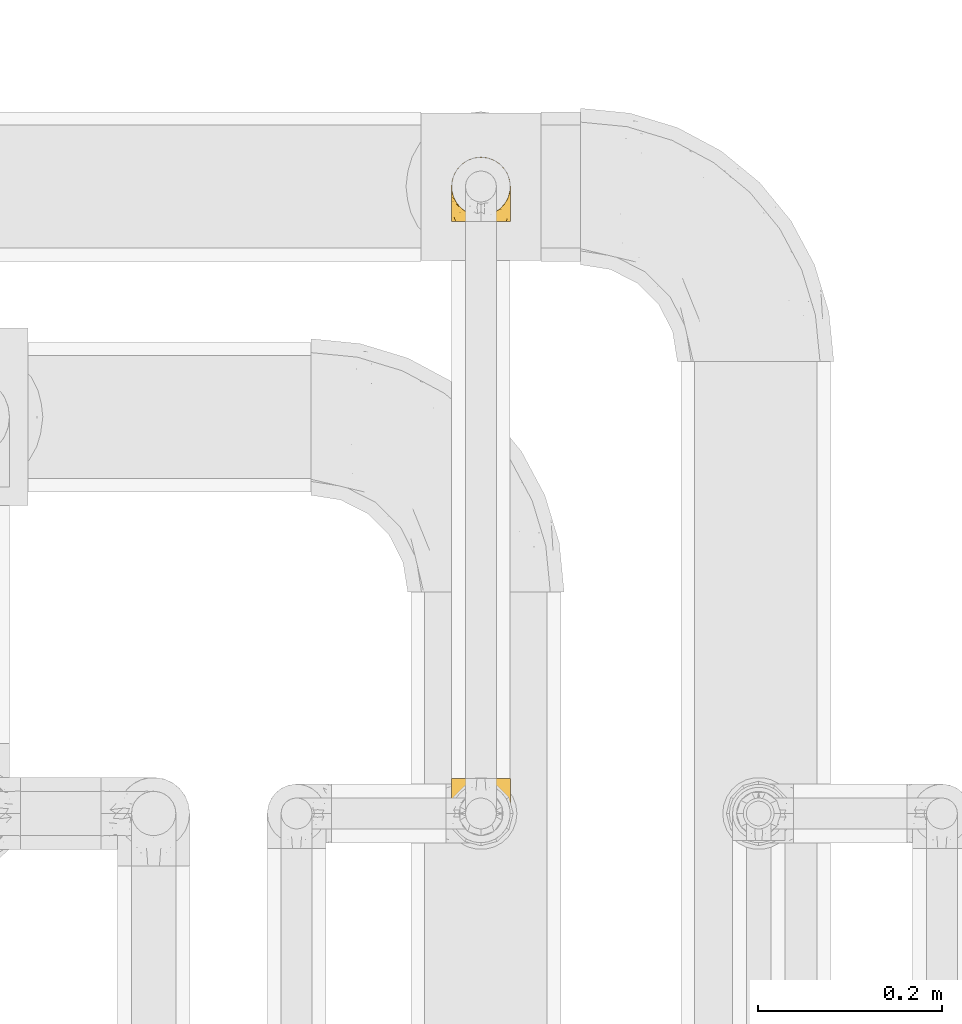
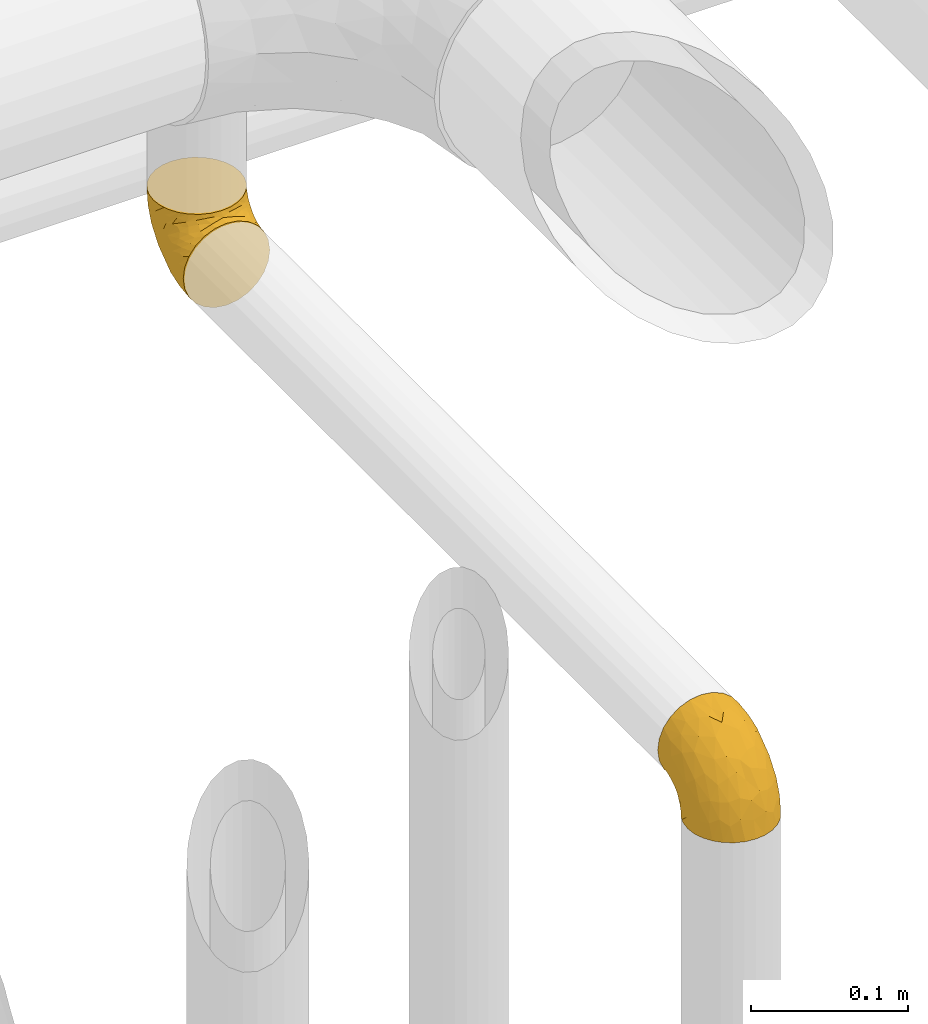
# One storey, part 504 of 827: 2 coverings.
"""IFC2X3 building model written with IfcOpenShell, lengths in millimetres."""

from ifc_helpers import new_model, entity, si_unit, converted_unit, derived_unit, direction, frame, origin, place, context, subcontext, project, spatial, faceted_brep, element, save


model = new_model("IFC2X3")

# Units and contexts
model_context = context("Model", 3, precision=0.01, world=origin(), true_north=direction((6.12303176911189e-17, 1.0)))
body_context = subcontext(model_context, "Body", "Model", "MODEL_VIEW")
ifc_project = project(units=[si_unit("LENGTHUNIT", "METRE", prefix="MILLI"), si_unit("AREAUNIT", "SQUARE_METRE"), si_unit("VOLUMEUNIT", "CUBIC_METRE"), converted_unit("PLANEANGLEUNIT", "DEGREE", entity("IfcRatioMeasure", 0.0174532925199433), si_unit("PLANEANGLEUNIT", "RADIAN"), dimensions=[0, 0, 0, 0, 0, 0, 0]), si_unit("MASSUNIT", "GRAM", prefix="KILO"), derived_unit("MASSDENSITYUNIT", [(si_unit("MASSUNIT", "GRAM", prefix="KILO"), 1), (si_unit("LENGTHUNIT", "METRE"), -3)]), derived_unit("MOMENTOFINERTIAUNIT", [(si_unit("LENGTHUNIT", "METRE"), 4)]), si_unit("TIMEUNIT", "SECOND"), si_unit("FREQUENCYUNIT", "HERTZ"), si_unit("THERMODYNAMICTEMPERATUREUNIT", "DEGREE_CELSIUS"), derived_unit("THERMALTRANSMITTANCEUNIT", [(si_unit("MASSUNIT", "GRAM", prefix="KILO"), 1), (si_unit("THERMODYNAMICTEMPERATUREUNIT", "KELVIN"), -1), (si_unit("TIMEUNIT", "SECOND"), -3)]), derived_unit("VOLUMETRICFLOWRATEUNIT", [(si_unit("LENGTHUNIT", "METRE"), 3), (si_unit("TIMEUNIT", "SECOND"), -1)]), derived_unit("MASSFLOWRATEUNIT", [(si_unit("MASSUNIT", "GRAM", prefix="KILO"), 1), (si_unit("TIMEUNIT", "SECOND"), -1)]), derived_unit("ROTATIONALFREQUENCYUNIT", [(si_unit("TIMEUNIT", "SECOND"), -1)]), si_unit("ELECTRICCURRENTUNIT", "AMPERE"), si_unit("ELECTRICVOLTAGEUNIT", "VOLT"), si_unit("POWERUNIT", "WATT"), si_unit("FORCEUNIT", "NEWTON", prefix="KILO"), si_unit("ILLUMINANCEUNIT", "LUX"), si_unit("LUMINOUSFLUXUNIT", "LUMEN"), si_unit("LUMINOUSINTENSITYUNIT", "CANDELA"), derived_unit("USERDEFINED", [(si_unit("MASSUNIT", "GRAM", prefix="KILO"), -1), (si_unit("LENGTHUNIT", "METRE"), -2), (si_unit("TIMEUNIT", "SECOND"), 3), (si_unit("LUMINOUSFLUXUNIT", "LUMEN"), 1)]), derived_unit("LINEARVELOCITYUNIT", [(si_unit("LENGTHUNIT", "METRE"), 1), (si_unit("TIMEUNIT", "SECOND"), -1)]), si_unit("PRESSUREUNIT", "PASCAL"), derived_unit("USERDEFINED", [(si_unit("LENGTHUNIT", "METRE"), -2), (si_unit("MASSUNIT", "GRAM", prefix="KILO"), 1), (si_unit("TIMEUNIT", "SECOND"), -2)]), derived_unit("LINEARFORCEUNIT", [(si_unit("MASSUNIT", "GRAM", prefix="KILO"), 1), (si_unit("LENGTHUNIT", "METRE"), 1), (si_unit("TIMEUNIT", "SECOND"), -2), (si_unit("LENGTHUNIT", "METRE"), -1)]), derived_unit("PLANARFORCEUNIT", [(si_unit("MASSUNIT", "GRAM", prefix="KILO"), 1), (si_unit("LENGTHUNIT", "METRE"), 1), (si_unit("TIMEUNIT", "SECOND"), -2), (si_unit("LENGTHUNIT", "METRE"), -2)])], contexts=[model_context])

# Site, building, storey
site_placement = place(None, origin())
site = spatial("IfcSite", under=ifc_project, at=site_placement, CompositionType="ELEMENT")
building_placement = place(site_placement, origin())
building = spatial("IfcBuilding", under=site, at=building_placement, CompositionType="ELEMENT")
storey_placement = place(building_placement, frame((0.0, 0.0, 28200.0)))
storey = spatial("IfcBuildingStorey", under=building, at=storey_placement, Name="08", CompositionType="ELEMENT", Elevation=28200.0)

# Coverings
covering_1_placement = place(storey_placement, frame((60119.69, 18140.5, 2466.55)))
element("IfcCovering", 1, at=covering_1_placement, inside=storey, Name=":ADSK_", ObjectType=":ADSK_", PredefinedType="INSULATION", context=body_context, shape_type="Brep", body=[
    faceted_brep([(40.53, 70.65, 71.45), (33.45, 71.45, 71.45), (26.35, 70.65, 71.45), (19.62, 68.29, 71.45), (13.58, 64.49, 71.45), (8.54, 59.45, 71.45), (4.75, 53.41, 71.45), (2.39, 46.68, 71.45), (1.6, 39.6, 71.45), (2.04, 35.69, 71.45), (2.39, 32.5, 71.45), (3.57, 29.14, 71.45), (4.75, 25.77, 71.45), (8.55, 19.73, 71.45), (13.59, 14.69, 71.45), (19.63, 10.9, 71.45), (26.36, 8.54, 71.45), (33.45, 7.75, 71.45), (40.54, 8.54, 71.45), (47.27, 10.9, 71.45), (53.31, 14.7, 71.45), (58.35, 19.74, 71.45), (62.14, 25.78, 71.45), (63.32, 29.15, 71.45), (64.5, 32.51, 71.45), (64.86, 35.69, 71.45), (65.08, 37.64, 71.45), (65.3, 39.6, 71.45), (64.5, 46.69, 71.45), (62.14, 53.42, 71.45), (58.34, 59.46, 71.45), (53.3, 64.5, 71.45), (47.26, 68.29, 71.45), (5.86, 1.6, 49.37), (4.27, 1.6, 45.53), (2.68, 1.6, 41.69), (2.11, 1.6, 37.37), (1.85, 1.6, 35.41), (1.6, 1.6, 33.45), (2.68, 1.6, 25.2), (5.86, 1.6, 17.52), (10.92, 1.6, 10.92), (17.52, 1.6, 5.86), (25.2, 1.6, 2.68), (33.45, 1.6, 1.6), (41.69, 1.6, 2.68), (49.37, 1.6, 5.86), (55.97, 1.6, 10.92), (61.03, 1.6, 17.52), (64.21, 1.6, 25.2), (65.3, 1.6, 33.45), (64.78, 1.6, 37.37), (64.21, 1.6, 41.69), (62.62, 1.6, 45.53), (61.03, 1.6, 49.37), (58.5, 1.6, 52.67), (55.97, 1.6, 55.97), (49.37, 1.6, 61.03), (41.69, 1.6, 64.21), (33.45, 1.6, 65.3), (25.2, 1.6, 64.21), (17.52, 1.6, 61.03), (10.92, 1.6, 55.97), (8.39, 1.6, 52.67), (64.03, 35.56, 39.1), (65.3, 34.5, 52.45), (65.3, 31.03, 48.97), (65.3, 27.55, 45.49), (65.3, 24.07, 42.01), (65.3, 20.6, 38.54), (33.45, 14.96, 4.25), (56.13, 32.2, 19.42), (61.0, 25.13, 22.87), (57.25, 17.37, 14.43), (44.44, 17.86, 5.53), (50.33, 27.91, 12.01), (51.72, 13.85, 8.54), (54.4, 61.37, 55.06), (41.87, 34.87, 11.33), (48.25, 44.22, 20.79), (64.6, 43.56, 56.32), (60.78, 40.93, 33.95), (61.71, 48.36, 47.18), (64.46, 17.22, 28.97), (55.78, 44.67, 28.68), (40.71, 63.86, 41.69), (42.87, 68.09, 55.32), (47.87, 61.87, 43.59), (62.12, 12.15, 20.67), (65.3, 17.69, 37.76), (65.3, 14.79, 36.98), (65.3, 11.89, 36.2), (65.3, 8.99, 35.43), (65.3, 7.14, 34.93), (65.3, 5.29, 34.44), (59.32, 56.77, 58.97), (49.35, 66.08, 59.39), (33.45, 68.79, 58.08), (62.53, 51.2, 59.72), (65.3, 39.1, 69.6), (65.3, 38.61, 67.75), (65.3, 37.61, 64.05), (65.3, 36.84, 61.15), (65.3, 36.06, 58.25), (65.3, 35.28, 55.35), (57.03, 54.2, 43.85), (52.84, 58.65, 44.13), (38.52, 21.36, 4.87), (33.45, 66.13, 44.71), (41.09, 46.99, 19.59), (33.45, 39.66, 14.48), (33.45, 50.99, 22.05), (44.35, 55.34, 29.9), (51.29, 53.83, 33.81), (33.45, 28.33, 6.91), (38.44, 55.34, 27.44), (33.45, 58.56, 33.38), (57.42, 6.06, 55.01), (61.06, 8.03, 50.28), (61.24, 11.06, 51.09), (64.58, 8.19, 40.86), (64.0, 10.89, 43.96), (64.21, 24.37, 52.27), (44.85, 9.23, 68.29), (61.42, 22.33, 62.01), (61.84, 24.59, 66.26), (59.03, 20.19, 67.36), (41.64, 5.45, 65.34), (38.8, 7.56, 68.62), (33.45, 5.94, 67.1), (54.12, 6.36, 58.52), (64.27, 29.84, 61.41), (63.33, 28.12, 66.44), (54.97, 14.94, 65.71), (54.91, 11.12, 60.56), (49.44, 9.87, 65.05), (49.79, 6.36, 61.9), (59.23, 16.34, 58.97), (62.42, 22.18, 57.67), (59.27, 18.62, 62.23), (64.6, 32.34, 65.15), (63.73, 15.29, 46.86), (50.25, 11.7, 67.24), (54.66, 13.14, 63.1), (62.35, 15.04, 50.81), (59.05, 10.61, 54.65), (64.34, 27.21, 55.33), (59.52, 14.05, 56.17), (63.71, 27.14, 59.8), (61.92, 5.74, 48.09), (64.52, 19.92, 46.45), (64.9, 23.61, 46.88), (63.33, 19.14, 50.93), (62.23, 20.12, 55.61), (22.04, 9.23, 68.29), (16.65, 11.69, 67.24), (17.46, 9.87, 65.05), (7.66, 16.33, 58.97), (12.13, 13.17, 62.98), (7.35, 18.65, 61.5), (25.25, 5.45, 65.34), (2.29, 32.33, 65.15), (1.6, 37.61, 64.05), (1.6, 36.84, 61.15), (1.6, 36.06, 58.25), (28.1, 7.56, 68.62), (4.51, 14.85, 50.62), (2.45, 17.26, 45.09), (5.62, 10.58, 50.82), (1.6, 3.44, 33.94), (1.6, 11.89, 36.2), (1.6, 8.99, 35.43), (1.6, 5.29, 34.44), (6.96, 5.65, 51.55), (4.16, 6.88, 46.52), (6.38, 14.93, 54.95), (7.84, 10.6, 54.65), (10.87, 11.09, 59.16), (17.1, 6.36, 61.9), (2.31, 8.19, 40.86), (1.6, 20.6, 38.54), (1.6, 24.07, 42.01), (2.62, 29.86, 61.39), (7.88, 20.16, 67.37), (5.05, 24.58, 66.23), (1.6, 38.61, 67.75), (1.6, 38.11, 65.9), (11.92, 14.93, 65.7), (1.6, 14.79, 36.98), (2.23, 12.32, 41.66), (2.95, 23.91, 53.21), (1.6, 27.55, 45.49), (3.29, 19.33, 50.1), (3.56, 28.11, 66.44), (9.57, 6.0, 55.11), (12.74, 6.44, 58.52), (2.39, 28.13, 55.59), (5.47, 22.32, 62.01), (1.6, 35.28, 55.35), (1.6, 34.5, 52.45), (3.46, 26.65, 60.71), (2.2, 15.34, 42.77), (1.6, 17.69, 37.76), (4.02, 10.31, 47.15), (1.6, 31.03, 48.97), (9.64, 17.37, 14.42), (4.35, 51.19, 59.72), (2.29, 43.56, 56.32), (2.43, 17.22, 28.97), (25.02, 34.87, 11.33), (22.45, 17.86, 5.53), (16.56, 27.92, 12.01), (5.89, 25.12, 22.86), (2.86, 35.57, 39.12), (6.1, 40.93, 33.96), (10.76, 32.19, 19.42), (28.37, 21.36, 4.87), (4.77, 12.15, 20.67), (15.17, 13.85, 8.55), (5.18, 48.35, 47.18), (7.56, 56.76, 58.97), (9.85, 54.19, 43.86), (19.01, 61.86, 43.58), (24.01, 68.09, 55.32), (26.18, 63.85, 41.67), (12.48, 61.36, 55.05), (25.8, 47.0, 19.59), (15.6, 53.81, 33.79), (14.04, 58.64, 44.12), (17.53, 66.07, 59.39), (18.64, 44.24, 20.81), (22.54, 55.34, 29.91), (11.1, 44.67, 28.68), (28.45, 55.34, 27.45)], [[[0, 1, 2, 3, 4, 5, 6, 7, 8, 9, 10, 11, 12, 13, 14, 15, 16, 17, 18, 19, 20, 21, 22, 23, 24, 25, 26, 27, 28, 29, 30, 31, 32]], [[33, 34, 35, 36, 37, 38, 39, 40, 41, 42, 43, 44, 45, 46, 47, 48, 49, 50, 51, 52, 53, 54, 55, 56, 57, 58, 59, 60, 61, 62, 63]], [[64, 65, 66, 67, 68, 69]], [[45, 44, 70]], [[71, 72, 73]], [[74, 75, 76]], [[77, 31, 30]], [[75, 78, 79]], [[27, 80, 28]], [[74, 46, 45]], [[64, 81, 82]], [[46, 76, 47]], [[83, 50, 49]], [[48, 47, 73]], [[71, 79, 84]], [[85, 86, 87]], [[49, 48, 88]], [[83, 69, 89, 90, 91, 92, 93, 94, 50]], [[95, 77, 30]], [[75, 74, 78]], [[87, 86, 96]], [[96, 86, 32]], [[96, 32, 31]], [[0, 86, 97]], [[83, 64, 69]], [[98, 80, 82]], [[73, 72, 88]], [[64, 80, 65]], [[1, 0, 97]], [[80, 27, 99, 100, 101, 102, 103, 104, 65]], [[77, 105, 106]], [[64, 82, 80]], [[70, 107, 45]], [[77, 95, 105]], [[82, 95, 98]], [[95, 30, 29]], [[74, 107, 78]], [[86, 0, 32]], [[72, 71, 81]], [[85, 108, 86]], [[76, 73, 47]], [[71, 84, 81]], [[109, 110, 111]], [[87, 112, 85]], [[79, 109, 112]], [[79, 112, 113]], [[88, 83, 49]], [[64, 83, 72]], [[31, 77, 96]], [[87, 96, 77]], [[98, 95, 29]], [[105, 95, 82]], [[81, 105, 82]], [[105, 84, 113]], [[29, 28, 98]], [[114, 107, 70]], [[80, 98, 28]], [[73, 75, 71]], [[79, 71, 75]], [[74, 76, 46]], [[73, 76, 75]], [[78, 107, 114]], [[45, 107, 74]], [[87, 113, 112]], [[115, 85, 112]], [[109, 79, 78]], [[113, 87, 106]], [[116, 115, 111]], [[116, 108, 85]], [[79, 113, 84]], [[109, 78, 110]], [[115, 109, 111]], [[85, 115, 116]], [[109, 115, 112]], [[72, 81, 64]], [[105, 81, 84]], [[73, 88, 48]], [[83, 88, 72]], [[86, 108, 97]], [[78, 114, 110]], [[113, 106, 105]], [[87, 77, 106]], [[117, 118, 119]], [[52, 120, 54, 53]], [[91, 120, 52]], [[91, 90, 120]], [[90, 121, 120]], [[122, 67, 66]], [[18, 123, 19]], [[124, 125, 126]], [[127, 59, 58]], [[128, 129, 127]], [[130, 57, 117]], [[131, 132, 125]], [[19, 133, 20]], [[128, 18, 17]], [[134, 135, 136]], [[137, 138, 139]], [[131, 103, 140]], [[22, 140, 23]], [[131, 65, 104, 103]], [[99, 27, 26, 25, 24, 101, 100]], [[141, 118, 121]], [[19, 123, 142]], [[52, 51, 50, 94, 93, 92, 91]], [[129, 128, 17]], [[117, 56, 118]], [[135, 134, 143]], [[139, 126, 133]], [[119, 144, 145]], [[127, 135, 123]], [[136, 58, 57]], [[101, 24, 23]], [[124, 138, 146]], [[140, 101, 23]], [[145, 147, 134]], [[140, 132, 131]], [[140, 103, 102, 101]], [[140, 22, 132]], [[146, 148, 124]], [[121, 69, 141]], [[55, 149, 118]], [[150, 151, 152]], [[147, 137, 134]], [[144, 150, 152]], [[152, 151, 122]], [[138, 122, 146]], [[59, 127, 129]], [[123, 18, 128]], [[58, 136, 127]], [[135, 127, 136]], [[121, 90, 89, 69]], [[120, 121, 149]], [[122, 66, 146]], [[153, 122, 138]], [[141, 69, 68]], [[127, 123, 128]], [[123, 135, 142]], [[143, 142, 135]], [[19, 142, 133]], [[66, 65, 146]], [[148, 65, 131]], [[22, 21, 132]], [[125, 132, 21]], [[126, 125, 21]], [[148, 125, 124]], [[21, 20, 126]], [[133, 126, 20]], [[139, 138, 124]], [[153, 138, 137]], [[126, 139, 124]], [[139, 133, 143]], [[147, 153, 137]], [[152, 122, 153]], [[134, 136, 130]], [[137, 139, 143]], [[144, 147, 145]], [[153, 147, 152]], [[65, 148, 146]], [[125, 148, 131]], [[141, 144, 119]], [[55, 54, 149]], [[137, 143, 134]], [[142, 143, 133]], [[130, 117, 145]], [[57, 56, 117]], [[134, 130, 145]], [[57, 130, 136]], [[150, 144, 141]], [[147, 144, 152]], [[141, 68, 150]], [[151, 68, 67]], [[117, 119, 145]], [[141, 119, 118]], [[68, 151, 150]], [[122, 151, 67]], [[118, 56, 55]], [[120, 149, 54]], [[118, 149, 121]], [[154, 155, 156]], [[157, 158, 159]], [[129, 160, 59]], [[161, 162, 163, 164]], [[165, 160, 129]], [[166, 167, 168]], [[169, 38, 37, 36, 35, 170, 171, 172]], [[63, 173, 174]], [[175, 176, 177]], [[60, 178, 61]], [[179, 35, 34, 33]], [[160, 60, 59]], [[180, 167, 181]], [[129, 17, 165]], [[182, 161, 164]], [[183, 13, 184]], [[9, 8, 185, 186, 162, 10]], [[187, 155, 15]], [[188, 179, 189]], [[187, 15, 14]], [[190, 191, 192]], [[182, 193, 161]], [[194, 176, 168]], [[176, 195, 177]], [[196, 190, 197]], [[11, 10, 162]], [[11, 161, 12]], [[187, 14, 183]], [[12, 161, 193]], [[156, 158, 177]], [[165, 17, 16]], [[194, 195, 176]], [[187, 159, 158]], [[179, 174, 189]], [[182, 164, 198, 199]], [[200, 199, 196]], [[193, 184, 13]], [[194, 168, 173]], [[201, 202, 189]], [[16, 154, 165]], [[160, 156, 178]], [[160, 165, 154]], [[178, 60, 160]], [[170, 35, 179]], [[188, 170, 179]], [[189, 174, 203]], [[174, 179, 33]], [[201, 189, 203]], [[181, 192, 191]], [[167, 180, 201]], [[192, 175, 190]], [[159, 190, 157]], [[15, 154, 16]], [[204, 196, 199]], [[204, 191, 190]], [[160, 154, 156]], [[15, 155, 154]], [[158, 155, 187]], [[203, 173, 168]], [[192, 181, 167]], [[190, 196, 204]], [[200, 196, 197]], [[184, 193, 182]], [[13, 12, 193]], [[200, 184, 182]], [[184, 200, 183]], [[187, 183, 197]], [[14, 13, 183]], [[162, 161, 11]], [[63, 62, 173]], [[174, 33, 63]], [[173, 62, 194]], [[174, 173, 203]], [[62, 61, 194]], [[195, 61, 178]], [[61, 195, 194]], [[177, 195, 178]], [[156, 177, 178]], [[175, 192, 166]], [[166, 168, 176]], [[167, 203, 168]], [[175, 166, 176]], [[167, 166, 192]], [[177, 157, 175]], [[190, 175, 157]], [[187, 197, 159]], [[190, 159, 197]], [[177, 158, 157]], [[155, 158, 156]], [[167, 201, 203]], [[200, 197, 183]], [[202, 201, 180]], [[202, 188, 189]], [[199, 200, 182]], [[41, 40, 205]], [[206, 207, 7]], [[208, 38, 169, 172, 171, 170, 188, 202, 180]], [[209, 210, 211]], [[212, 213, 214]], [[212, 215, 205]], [[43, 210, 216]], [[217, 40, 39]], [[216, 114, 70]], [[208, 213, 212]], [[205, 40, 217]], [[218, 42, 41]], [[216, 209, 114]], [[42, 218, 210]], [[214, 213, 219]], [[219, 220, 221]], [[199, 207, 213]], [[213, 207, 219]], [[8, 7, 207]], [[222, 223, 224]], [[4, 225, 5]], [[2, 97, 223]], [[110, 226, 111]], [[225, 220, 5]], [[227, 221, 228]], [[223, 229, 3]], [[2, 223, 3]], [[230, 231, 226]], [[224, 223, 108]], [[42, 210, 43]], [[230, 209, 211]], [[222, 225, 229]], [[38, 208, 39]], [[3, 229, 4]], [[213, 180, 181, 191, 204, 199]], [[220, 206, 6]], [[5, 220, 6]], [[207, 199, 198, 164, 163, 162, 186, 185, 8]], [[212, 214, 215]], [[218, 205, 211]], [[211, 215, 230]], [[226, 110, 209]], [[222, 231, 227]], [[222, 224, 231]], [[213, 208, 180]], [[217, 208, 212]], [[222, 229, 223]], [[225, 4, 229]], [[221, 220, 225]], [[206, 220, 219]], [[228, 221, 225]], [[214, 221, 232]], [[207, 206, 219]], [[44, 43, 70]], [[7, 6, 206]], [[230, 215, 232]], [[211, 205, 215]], [[205, 218, 41]], [[210, 218, 211]], [[43, 216, 70]], [[209, 216, 210]], [[233, 116, 111]], [[230, 232, 227]], [[224, 116, 233]], [[230, 226, 209]], [[224, 108, 116]], [[230, 227, 231]], [[221, 227, 232]], [[233, 226, 231]], [[225, 222, 228]], [[226, 233, 111]], [[224, 233, 231]], [[221, 214, 219]], [[214, 232, 215]], [[208, 217, 39]], [[205, 217, 212]], [[97, 2, 1]], [[97, 108, 223]], [[110, 114, 209]], [[227, 228, 222]]]),
])
covering_2_placement = place(storey_placement, frame((60119.69, 17466.55, 2460.4)))
element("IfcCovering", 2, at=covering_2_placement, inside=storey, Name=":ADSK_", ObjectType=":ADSK_", PredefinedType="INSULATION", context=body_context, shape_type="Brep", body=[
    faceted_brep([(40.53, 2.39, 1.6), (33.45, 1.6, 1.6), (26.35, 2.39, 1.6), (19.62, 4.75, 1.6), (13.58, 8.55, 1.6), (8.54, 13.59, 1.6), (4.75, 19.63, 1.6), (2.39, 26.36, 1.6), (1.6, 33.45, 1.6), (2.04, 37.35, 1.6), (2.39, 40.54, 1.6), (3.57, 43.9, 1.6), (4.75, 47.27, 1.6), (8.55, 53.31, 1.6), (13.59, 58.35, 1.6), (19.63, 62.14, 1.6), (26.36, 64.5, 1.6), (33.45, 65.3, 1.6), (40.54, 64.5, 1.6), (47.27, 62.14, 1.6), (53.31, 58.34, 1.6), (58.35, 53.3, 1.6), (62.14, 47.26, 1.6), (63.32, 43.89, 1.6), (64.5, 40.53, 1.6), (64.86, 37.35, 1.6), (65.08, 35.4, 1.6), (65.3, 33.45, 1.6), (64.5, 26.35, 1.6), (62.14, 19.62, 1.6), (58.34, 13.58, 1.6), (53.3, 8.54, 1.6), (47.26, 4.75, 1.6), (5.86, 71.45, 23.67), (4.27, 71.45, 27.51), (2.68, 71.45, 31.35), (2.11, 71.45, 35.67), (1.85, 71.45, 37.63), (1.6, 71.45, 39.6), (2.68, 71.45, 47.84), (5.86, 71.45, 55.52), (10.92, 71.45, 62.12), (17.52, 71.45, 67.18), (25.2, 71.45, 70.36), (33.45, 71.45, 71.45), (41.69, 71.45, 70.36), (49.37, 71.45, 67.18), (55.97, 71.45, 62.12), (61.03, 71.45, 55.52), (64.21, 71.45, 47.84), (65.3, 71.45, 39.6), (64.78, 71.45, 35.67), (64.21, 71.45, 31.35), (62.62, 71.45, 27.51), (61.03, 71.45, 23.67), (58.5, 71.45, 20.37), (55.97, 71.45, 17.07), (49.37, 71.45, 12.01), (41.69, 71.45, 8.83), (33.45, 71.45, 7.75), (25.2, 71.45, 8.83), (17.52, 71.45, 12.01), (10.92, 71.45, 17.07), (8.39, 71.45, 20.37), (64.03, 37.48, 33.94), (65.3, 38.54, 20.6), (65.3, 42.01, 24.07), (65.3, 45.49, 27.55), (65.3, 48.97, 31.03), (65.3, 52.45, 34.5), (33.45, 58.08, 68.79), (56.13, 40.84, 53.62), (61.0, 47.91, 50.17), (57.25, 55.67, 58.62), (44.44, 55.18, 67.51), (50.33, 45.13, 61.03), (51.72, 59.19, 64.5), (54.4, 11.67, 17.98), (41.87, 38.17, 61.71), (48.25, 28.82, 52.25), (64.6, 29.48, 16.72), (60.78, 32.11, 39.09), (61.71, 24.68, 25.86), (64.46, 55.82, 44.07), (55.78, 28.37, 44.36), (40.71, 9.18, 31.35), (42.87, 4.95, 17.72), (47.87, 11.17, 29.45), (62.12, 60.89, 52.37), (65.3, 55.35, 35.28), (65.3, 58.25, 36.06), (65.3, 61.15, 36.84), (65.3, 64.05, 37.61), (65.3, 65.9, 38.11), (65.3, 67.75, 38.61), (59.32, 16.27, 14.07), (49.35, 6.97, 13.65), (33.45, 4.25, 14.96), (62.53, 21.84, 13.32), (65.3, 33.94, 3.44), (65.3, 34.44, 5.29), (65.3, 35.43, 8.99), (65.3, 36.2, 11.89), (65.3, 36.98, 14.79), (65.3, 37.76, 17.69), (57.03, 18.84, 29.19), (52.84, 14.39, 28.91), (38.52, 51.68, 68.17), (33.45, 6.91, 28.33), (41.09, 26.05, 53.45), (33.45, 33.38, 58.56), (33.45, 22.05, 50.99), (44.35, 17.7, 43.14), (51.29, 19.21, 39.23), (33.45, 44.71, 66.13), (38.44, 17.7, 45.6), (33.45, 14.48, 39.66), (57.42, 66.98, 18.04), (61.06, 65.01, 22.76), (61.24, 61.98, 21.95), (64.58, 64.85, 32.18), (64.0, 62.15, 29.08), (64.21, 48.67, 20.77), (44.85, 63.81, 4.75), (61.42, 50.71, 11.03), (61.84, 48.45, 6.78), (59.03, 52.85, 5.68), (41.64, 67.6, 7.71), (38.8, 65.48, 4.42), (33.45, 67.1, 5.94), (54.12, 66.68, 14.52), (64.27, 43.2, 11.63), (63.33, 44.92, 6.6), (54.97, 58.1, 7.33), (54.91, 61.92, 12.48), (49.44, 63.17, 7.99), (49.79, 66.68, 11.14), (59.23, 56.7, 14.07), (62.42, 50.86, 15.37), (59.27, 54.42, 10.81), (64.6, 40.7, 7.89), (63.73, 57.76, 26.18), (50.25, 61.34, 5.8), (54.66, 59.9, 9.94), (62.35, 58.0, 22.23), (59.05, 62.43, 18.39), (64.34, 45.83, 17.71), (59.52, 58.99, 16.87), (63.71, 45.9, 13.24), (61.92, 67.3, 24.95), (64.52, 53.12, 26.59), (64.9, 49.43, 26.16), (63.33, 53.9, 22.11), (62.23, 52.92, 17.43), (22.04, 63.81, 4.75), (16.65, 61.35, 5.8), (17.46, 63.17, 7.99), (7.66, 56.72, 14.07), (12.13, 59.87, 10.06), (7.35, 54.39, 11.54), (25.25, 67.59, 7.71), (2.29, 40.71, 7.89), (1.6, 35.43, 8.99), (1.6, 36.2, 11.89), (1.6, 36.98, 14.79), (28.1, 65.48, 4.42), (4.51, 58.19, 22.42), (2.45, 55.78, 27.95), (5.62, 62.46, 22.22), (1.6, 69.6, 39.1), (1.6, 61.15, 36.84), (1.6, 64.05, 37.61), (1.6, 67.75, 38.61), (6.96, 67.39, 21.49), (4.16, 66.16, 26.52), (6.38, 58.11, 18.09), (7.84, 62.44, 18.39), (10.87, 61.95, 13.88), (17.1, 66.68, 11.14), (2.31, 64.85, 32.18), (1.6, 52.45, 34.5), (1.6, 48.97, 31.03), (2.62, 43.18, 11.65), (7.88, 52.88, 5.67), (5.05, 48.46, 6.81), (1.6, 34.44, 5.29), (1.6, 34.93, 7.14), (11.92, 58.11, 7.34), (1.6, 58.25, 36.06), (2.23, 60.72, 31.38), (2.95, 49.13, 19.83), (1.6, 45.49, 27.55), (3.29, 53.71, 22.94), (3.56, 44.93, 6.6), (9.57, 67.04, 17.93), (12.74, 66.6, 14.52), (2.39, 44.91, 17.45), (5.47, 50.72, 11.03), (1.6, 37.76, 17.69), (1.6, 38.54, 20.6), (3.46, 46.39, 12.33), (2.2, 57.7, 30.27), (1.6, 55.35, 35.28), (4.02, 62.73, 25.9), (1.6, 42.01, 24.07), (9.64, 55.67, 58.62), (4.35, 21.85, 13.32), (2.29, 29.49, 16.72), (2.43, 55.82, 44.07), (25.02, 38.17, 61.71), (22.45, 55.18, 67.51), (16.56, 45.12, 61.03), (5.89, 47.92, 50.18), (2.86, 37.47, 33.92), (6.1, 32.11, 39.08), (10.76, 40.85, 53.62), (28.37, 51.68, 68.17), (4.77, 60.89, 52.37), (15.17, 59.19, 64.5), (5.18, 24.69, 25.86), (7.56, 16.28, 14.07), (9.85, 18.85, 29.18), (19.01, 11.19, 29.46), (24.01, 4.95, 17.73), (26.18, 9.19, 31.37), (12.48, 11.68, 17.99), (25.8, 26.05, 53.45), (15.6, 19.23, 39.25), (14.04, 14.4, 28.92), (17.53, 6.97, 13.65), (18.64, 28.8, 52.23), (22.54, 17.7, 43.13), (11.1, 28.37, 44.36), (28.45, 17.7, 45.6)], [[[0, 1, 2, 3, 4, 5, 6, 7, 8, 9, 10, 11, 12, 13, 14, 15, 16, 17, 18, 19, 20, 21, 22, 23, 24, 25, 26, 27, 28, 29, 30, 31, 32]], [[33, 34, 35, 36, 37, 38, 39, 40, 41, 42, 43, 44, 45, 46, 47, 48, 49, 50, 51, 52, 53, 54, 55, 56, 57, 58, 59, 60, 61, 62, 63]], [[64, 65, 66, 67, 68, 69]], [[45, 44, 70]], [[71, 72, 73]], [[74, 75, 76]], [[77, 31, 30]], [[75, 78, 79]], [[27, 80, 28]], [[74, 46, 45]], [[64, 81, 82]], [[46, 76, 47]], [[83, 50, 49]], [[48, 47, 73]], [[71, 79, 84]], [[85, 86, 87]], [[49, 48, 88]], [[83, 69, 89, 90, 91, 92, 93, 94, 50]], [[95, 77, 30]], [[75, 74, 78]], [[87, 86, 96]], [[96, 86, 32]], [[96, 32, 31]], [[0, 86, 97]], [[83, 64, 69]], [[98, 80, 82]], [[73, 72, 88]], [[64, 80, 65]], [[1, 0, 97]], [[80, 27, 99, 100, 101, 102, 103, 104, 65]], [[77, 105, 106]], [[64, 82, 80]], [[70, 107, 45]], [[77, 95, 105]], [[82, 95, 98]], [[95, 30, 29]], [[74, 107, 78]], [[86, 0, 32]], [[72, 71, 81]], [[85, 108, 86]], [[76, 73, 47]], [[71, 84, 81]], [[109, 110, 111]], [[87, 112, 85]], [[79, 109, 112]], [[79, 112, 113]], [[88, 83, 49]], [[64, 83, 72]], [[31, 77, 96]], [[87, 96, 77]], [[98, 95, 29]], [[105, 95, 82]], [[81, 105, 82]], [[105, 84, 113]], [[29, 28, 98]], [[114, 107, 70]], [[80, 98, 28]], [[73, 75, 71]], [[79, 71, 75]], [[74, 76, 46]], [[73, 76, 75]], [[78, 107, 114]], [[45, 107, 74]], [[87, 113, 112]], [[115, 85, 112]], [[109, 79, 78]], [[113, 87, 106]], [[116, 115, 111]], [[116, 108, 85]], [[79, 113, 84]], [[109, 78, 110]], [[115, 109, 111]], [[85, 115, 116]], [[109, 115, 112]], [[72, 81, 64]], [[105, 81, 84]], [[73, 88, 48]], [[83, 88, 72]], [[86, 108, 97]], [[78, 114, 110]], [[113, 106, 105]], [[87, 77, 106]], [[117, 118, 119]], [[52, 120, 54, 53]], [[91, 120, 52]], [[91, 90, 120]], [[90, 121, 120]], [[122, 67, 66]], [[18, 123, 19]], [[124, 125, 126]], [[127, 59, 58]], [[128, 129, 127]], [[130, 57, 117]], [[131, 132, 125]], [[19, 133, 20]], [[128, 18, 17]], [[134, 135, 136]], [[137, 138, 139]], [[131, 103, 140]], [[22, 140, 23]], [[131, 65, 104, 103]], [[99, 27, 26, 25, 24, 101, 100]], [[141, 118, 121]], [[19, 123, 142]], [[52, 51, 50, 94, 93, 92, 91]], [[129, 128, 17]], [[117, 56, 118]], [[135, 134, 143]], [[139, 126, 133]], [[119, 144, 145]], [[127, 135, 123]], [[136, 58, 57]], [[101, 24, 23]], [[124, 138, 146]], [[140, 101, 23]], [[145, 147, 134]], [[140, 132, 131]], [[140, 103, 102, 101]], [[140, 22, 132]], [[146, 148, 124]], [[121, 69, 141]], [[55, 149, 118]], [[150, 151, 152]], [[147, 137, 134]], [[144, 150, 152]], [[152, 151, 122]], [[138, 122, 146]], [[59, 127, 129]], [[123, 18, 128]], [[58, 136, 127]], [[135, 127, 136]], [[121, 90, 89, 69]], [[120, 121, 149]], [[122, 66, 146]], [[153, 122, 138]], [[141, 69, 68]], [[127, 123, 128]], [[123, 135, 142]], [[143, 142, 135]], [[19, 142, 133]], [[66, 65, 146]], [[148, 65, 131]], [[22, 21, 132]], [[125, 132, 21]], [[126, 125, 21]], [[148, 125, 124]], [[21, 20, 126]], [[133, 126, 20]], [[139, 138, 124]], [[153, 138, 137]], [[126, 139, 124]], [[139, 133, 143]], [[147, 153, 137]], [[152, 122, 153]], [[134, 136, 130]], [[137, 139, 143]], [[144, 147, 145]], [[153, 147, 152]], [[65, 148, 146]], [[125, 148, 131]], [[141, 144, 119]], [[55, 54, 149]], [[137, 143, 134]], [[142, 143, 133]], [[130, 117, 145]], [[57, 56, 117]], [[134, 130, 145]], [[57, 130, 136]], [[150, 144, 141]], [[147, 144, 152]], [[141, 68, 150]], [[151, 68, 67]], [[117, 119, 145]], [[141, 119, 118]], [[68, 151, 150]], [[122, 151, 67]], [[118, 56, 55]], [[120, 149, 54]], [[118, 149, 121]], [[154, 155, 156]], [[157, 158, 159]], [[129, 160, 59]], [[161, 162, 163, 164]], [[165, 160, 129]], [[166, 167, 168]], [[169, 38, 37, 36, 35, 170, 171, 172]], [[63, 173, 174]], [[175, 176, 177]], [[60, 178, 61]], [[179, 35, 34, 33]], [[160, 60, 59]], [[180, 167, 181]], [[129, 17, 165]], [[182, 161, 164]], [[183, 13, 184]], [[9, 8, 185, 186, 162, 10]], [[187, 155, 15]], [[188, 179, 189]], [[187, 15, 14]], [[190, 191, 192]], [[182, 193, 161]], [[194, 176, 168]], [[176, 195, 177]], [[196, 190, 197]], [[11, 10, 162]], [[11, 161, 12]], [[187, 14, 183]], [[12, 161, 193]], [[156, 158, 177]], [[165, 17, 16]], [[194, 195, 176]], [[187, 159, 158]], [[179, 174, 189]], [[182, 164, 198, 199]], [[200, 199, 196]], [[193, 184, 13]], [[194, 168, 173]], [[201, 202, 189]], [[16, 154, 165]], [[160, 156, 178]], [[160, 165, 154]], [[178, 60, 160]], [[170, 35, 179]], [[188, 170, 179]], [[189, 174, 203]], [[174, 179, 33]], [[201, 189, 203]], [[181, 192, 191]], [[167, 180, 201]], [[192, 175, 190]], [[159, 190, 157]], [[15, 154, 16]], [[204, 196, 199]], [[204, 191, 190]], [[160, 154, 156]], [[15, 155, 154]], [[158, 155, 187]], [[203, 173, 168]], [[192, 181, 167]], [[190, 196, 204]], [[200, 196, 197]], [[184, 193, 182]], [[13, 12, 193]], [[200, 184, 182]], [[184, 200, 183]], [[187, 183, 197]], [[14, 13, 183]], [[162, 161, 11]], [[63, 62, 173]], [[174, 33, 63]], [[173, 62, 194]], [[174, 173, 203]], [[62, 61, 194]], [[195, 61, 178]], [[61, 195, 194]], [[177, 195, 178]], [[156, 177, 178]], [[175, 192, 166]], [[166, 168, 176]], [[167, 203, 168]], [[175, 166, 176]], [[167, 166, 192]], [[177, 157, 175]], [[190, 175, 157]], [[187, 197, 159]], [[190, 159, 197]], [[177, 158, 157]], [[155, 158, 156]], [[167, 201, 203]], [[200, 197, 183]], [[202, 201, 180]], [[202, 188, 189]], [[199, 200, 182]], [[41, 40, 205]], [[206, 207, 7]], [[208, 38, 169, 172, 171, 170, 188, 202, 180]], [[209, 210, 211]], [[212, 213, 214]], [[212, 215, 205]], [[43, 210, 216]], [[217, 40, 39]], [[216, 114, 70]], [[208, 213, 212]], [[205, 40, 217]], [[218, 42, 41]], [[216, 209, 114]], [[42, 218, 210]], [[214, 213, 219]], [[219, 220, 221]], [[199, 207, 213]], [[213, 207, 219]], [[8, 7, 207]], [[222, 223, 224]], [[4, 225, 5]], [[2, 97, 223]], [[110, 226, 111]], [[225, 220, 5]], [[227, 221, 228]], [[223, 229, 3]], [[2, 223, 3]], [[230, 231, 226]], [[224, 223, 108]], [[42, 210, 43]], [[230, 209, 211]], [[222, 225, 229]], [[38, 208, 39]], [[3, 229, 4]], [[213, 180, 181, 191, 204, 199]], [[220, 206, 6]], [[5, 220, 6]], [[207, 199, 198, 164, 163, 162, 186, 185, 8]], [[212, 214, 215]], [[218, 205, 211]], [[211, 215, 230]], [[226, 110, 209]], [[222, 231, 227]], [[222, 224, 231]], [[213, 208, 180]], [[217, 208, 212]], [[222, 229, 223]], [[225, 4, 229]], [[221, 220, 225]], [[206, 220, 219]], [[228, 221, 225]], [[214, 221, 232]], [[207, 206, 219]], [[44, 43, 70]], [[7, 6, 206]], [[230, 215, 232]], [[211, 205, 215]], [[205, 218, 41]], [[210, 218, 211]], [[43, 216, 70]], [[209, 216, 210]], [[233, 116, 111]], [[230, 232, 227]], [[224, 116, 233]], [[230, 226, 209]], [[224, 108, 116]], [[230, 227, 231]], [[221, 227, 232]], [[233, 226, 231]], [[225, 222, 228]], [[226, 233, 111]], [[224, 233, 231]], [[221, 214, 219]], [[214, 232, 215]], [[208, 217, 39]], [[205, 217, 212]], [[97, 2, 1]], [[97, 108, 223]], [[110, 114, 209]], [[227, 228, 222]]]),
])

save(model, "model.ifc")
